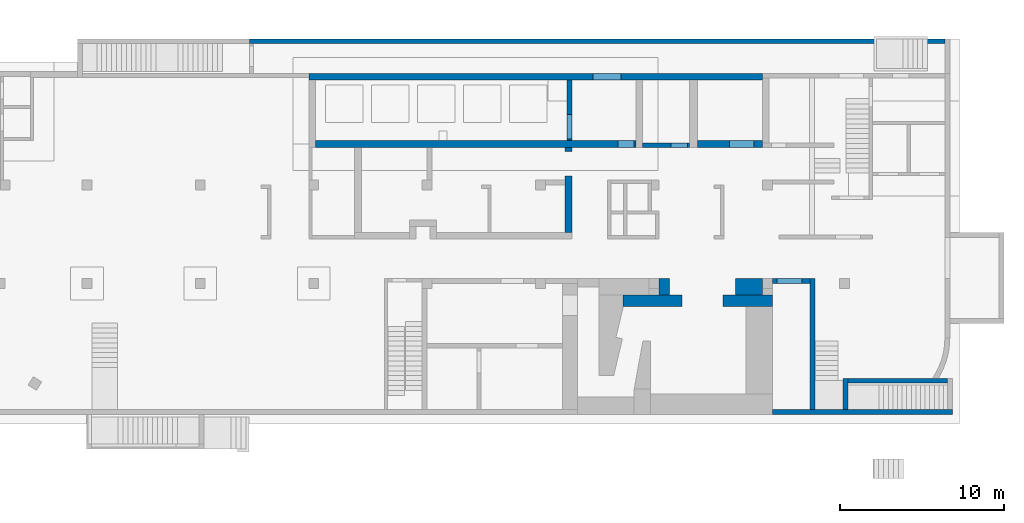
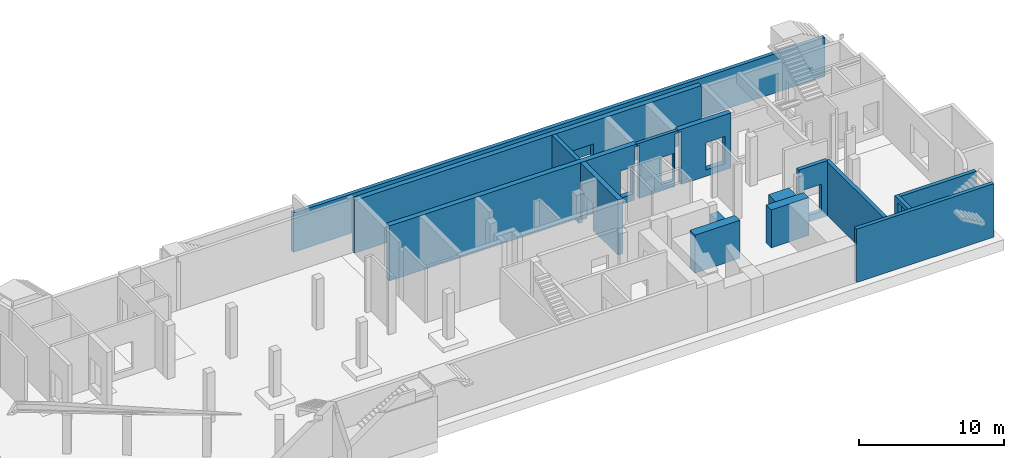
# One storey, part 7 of 9: 16 walls, 8 openings.
"""IFC4 building model written with IfcOpenShell, lengths in millimetres."""

from ifc_helpers import new_model, entity, si_unit, converted_unit, derived_unit, direction, frame, origin, place, context, subcontext, project, spatial, indexed_curve, outline, extrude, triangles, polygons, material, type_object, element, save


model = new_model("IFC4")

# Units and contexts
model_context = context("Model", 3, precision=0.01, world=origin(), true_north=direction((6.12303176911189e-17, 1.0)))
plan_context = context("Plan", 3, precision=0.01, world=origin(), true_north=direction((6.12303176911189e-17, 1.0)))
body_context = subcontext(model_context, "Body", "Model", "MODEL_VIEW")
ifc_project = project(units=[si_unit("LENGTHUNIT", "METRE", prefix="MILLI"), si_unit("AREAUNIT", "SQUARE_METRE"), si_unit("VOLUMEUNIT", "CUBIC_METRE"), converted_unit("PLANEANGLEUNIT", "DEGREE", entity("IfcRatioMeasure", 0.0174532925199433), si_unit("PLANEANGLEUNIT", "RADIAN"), dimensions=[0, 0, 0, 0, 0, 0, 0]), si_unit("MASSUNIT", "GRAM", prefix="KILO"), derived_unit("MASSDENSITYUNIT", [(si_unit("MASSUNIT", "GRAM", prefix="KILO"), 1), (si_unit("LENGTHUNIT", "METRE"), -3)]), derived_unit("MOMENTOFINERTIAUNIT", [(si_unit("LENGTHUNIT", "METRE"), 4)]), si_unit("TIMEUNIT", "SECOND"), si_unit("FREQUENCYUNIT", "HERTZ"), si_unit("THERMODYNAMICTEMPERATUREUNIT", "DEGREE_CELSIUS"), derived_unit("THERMALTRANSMITTANCEUNIT", [(si_unit("MASSUNIT", "GRAM", prefix="KILO"), 1), (si_unit("THERMODYNAMICTEMPERATUREUNIT", "KELVIN"), -1), (si_unit("TIMEUNIT", "SECOND"), -3)]), derived_unit("VOLUMETRICFLOWRATEUNIT", [(si_unit("LENGTHUNIT", "METRE"), 3), (si_unit("TIMEUNIT", "SECOND"), -1)]), derived_unit("MASSFLOWRATEUNIT", [(si_unit("MASSUNIT", "GRAM", prefix="KILO"), 1), (si_unit("TIMEUNIT", "SECOND"), -1)]), derived_unit("ROTATIONALFREQUENCYUNIT", [(si_unit("TIMEUNIT", "SECOND"), -1)]), si_unit("ELECTRICCURRENTUNIT", "AMPERE"), si_unit("ELECTRICVOLTAGEUNIT", "VOLT"), si_unit("POWERUNIT", "WATT"), si_unit("FORCEUNIT", "NEWTON", prefix="KILO"), si_unit("ILLUMINANCEUNIT", "LUX"), si_unit("LUMINOUSFLUXUNIT", "LUMEN"), si_unit("LUMINOUSINTENSITYUNIT", "CANDELA"), derived_unit("USERDEFINED", [(si_unit("MASSUNIT", "GRAM", prefix="KILO"), -1), (si_unit("LENGTHUNIT", "METRE"), -2), (si_unit("TIMEUNIT", "SECOND"), 3), (si_unit("LUMINOUSFLUXUNIT", "LUMEN"), 1)]), derived_unit("LINEARVELOCITYUNIT", [(si_unit("LENGTHUNIT", "METRE"), 1), (si_unit("TIMEUNIT", "SECOND"), -1)]), si_unit("PRESSUREUNIT", "PASCAL"), derived_unit("USERDEFINED", [(si_unit("LENGTHUNIT", "METRE"), -2), (si_unit("MASSUNIT", "GRAM", prefix="KILO"), 1), (si_unit("TIMEUNIT", "SECOND"), -2)]), derived_unit("LINEARFORCEUNIT", [(si_unit("MASSUNIT", "GRAM", prefix="KILO"), 1), (si_unit("LENGTHUNIT", "METRE"), 1), (si_unit("TIMEUNIT", "SECOND"), -2), (si_unit("LENGTHUNIT", "METRE"), -1)]), derived_unit("PLANARFORCEUNIT", [(si_unit("MASSUNIT", "GRAM", prefix="KILO"), 1), (si_unit("LENGTHUNIT", "METRE"), 1), (si_unit("TIMEUNIT", "SECOND"), -2), (si_unit("LENGTHUNIT", "METRE"), -2)])], contexts=[model_context, plan_context])

# Site, building, storey
site_placement = place(None, origin())
site = spatial("IfcSite", under=ifc_project, at=site_placement, CompositionType="ELEMENT")
building_placement = place(site_placement, origin())
building = spatial("IfcBuilding", under=site, at=building_placement, CompositionType="ELEMENT")
storey_placement = place(building_placement, frame((0.0, 0.0, -4900.0)))
storey = spatial("IfcBuildingStorey", under=building, at=storey_placement, CompositionType="ELEMENT", Elevation=-4900.0)

# Walls
ifc_material = material()
wall_type_1 = type_object("IfcWallType", Name=":ADSK_ 25_300", PredefinedType="STANDARD")
wall_1_placement = place(storey_placement, frame((62870.0, -100.0, 0.0)))
element("IfcWall", 1, at=wall_1_placement, inside=storey, type_object=wall_type_1, material=ifc_material, Name=":ADSK_ 25_300", ObjectType=":ADSK_ 25_300", PredefinedType="NOTDEFINED", context=body_context, shape_type="Tessellation", body=[
    polygons([(1.69593855051474e-12, -150.0, 0.0), (10955.0, -150.0, 0.0), (10955.0, -150.0, 4500.0), (4600.0, -150.0, 4500.0), (1.69593855051474e-12, -150.0, 4500.0), (1.69593855051474e-12, -150.0, 3200.0), (-3.39181412269712e-13, 150.0, 0.0), (-3.39181412269712e-13, 150.0, 4500.0), (2300.0, 150.0, 4500.0), (2600.0, 150.0, 4500.0), (4299.99999999999, 150.0, 4500.0), (4600.00000000002, 150.000000000001, 4500.0), (10955.0, 150.0, 4500.0), (10955.0, 150.0, 4229.99999999996), (10955.0, 150.0, 0.0), (10655.0, 150.0, 0.0), (4599.99999999999, 150.0, 0.0), (4299.99999999999, 150.0, 0.0), (2600.0, 150.0, 0.0), (2300.0, 150.0, 0.0)], [[[1, 2, 3, 4, 5, 6]], [[7, 8, 9, 10, 11, 12, 13, 14, 15, 16, 17, 18, 19, 20]], [[2, 1, 7, 20, 19, 18, 17, 16, 15]], [[1, 6, 5, 8, 7]], [[3, 2, 15, 14, 13]], [[4, 3, 13, 12]], [[5, 4, 12, 11, 10, 9, 8]]], closed=True),
])
wall_2_placement = place(storey_placement, frame((65320.0, 50.0, 0.0), z_axis=(0.0, 0.0, 1.0), x_axis=(0.0, 1.0, 0.0)))
element("IfcWall", 2, at=wall_2_placement, inside=storey, type_object=wall_type_1, material=ifc_material, Name=":ADSK_ 25_300", ObjectType=":ADSK_ 25_300", PredefinedType="NOTDEFINED", context=body_context, shape_type="Tessellation", body=[
    polygons([(1.01518793371724e-13, -150.000000000001, 0.0), (7950.00000000001, -150.000000000001, 0.0), (7950.00000000001, -150.000000000001, 4500.0), (3.38395977905748e-14, -150.000000000001, 4500.0), (2.16573425859679e-12, 150.000000000001, 0.0), (2.14035456025385e-12, 150.000000000001, 4500.0), (7950.00000000001, 150.000000000001, 4500.0), (7950.00000000001, 150.000000000001, 0.0), (7650.00000000001, 150.000000000001, 0.0)], [[[1, 2, 3, 4]], [[5, 6, 7, 8, 9]], [[2, 1, 5, 9, 8]], [[3, 2, 8, 7]], [[1, 4, 6, 5]], [[4, 3, 7, 6]]], closed=True),
])

# Wall, opening
wall_3_placement = place(storey_placement, frame((62870.0, 7850.0, 0.0)))
wall_3 = element("IfcWall", 3, at=wall_3_placement, inside=storey, type_object=wall_type_1, material=ifc_material, Name=":ADSK_ 25_300", ObjectType=":ADSK_ 25_300", PredefinedType="NOTDEFINED", context=body_context, shape_type="Tessellation", body=[
    polygons([(2.00999830337293e-12, -149.999999999999, 0.0), (2299.99999999999, -149.999999999998, 0.0), (2299.99999999999, -149.999999999998, 4650.0), (2.00999830337293e-12, -149.999999999999, 4650.0), (299.999999999986, -149.999999999997, 2829.99999999805), (1799.99999999999, -149.999999999998, 2829.99999999804), (1799.99999999999, -149.999999999998, 550.0), (299.999999999986, -149.999999999997, 550.0), (2299.99999999999, 150.000000000002, 0.0), (4.00724627324388e-13, 150.000000000002, 0.0), (4.00724627324396e-13, 150.000000000001, 3200.0), (4.00724627324388e-13, 150.000000000002, 4650.0), (2299.99999999999, 150.000000000002, 4650.0), (2299.99999999999, 150.000000000002, 4500.0), (1799.99999999999, 150.000000000001, 2829.99999999804), (299.999999999993, 150.000000000002, 2829.99999999805), (299.999999999984, 150.000000000002, 550.0), (1799.99999999999, 150.000000000001, 550.0)], [[[1, 2, 3, 4], [5, 6, 7, 8]], [[9, 10, 11, 12, 13, 14], [15, 16, 17, 18]], [[2, 1, 10, 9]], [[4, 3, 13, 12]], [[1, 4, 12, 11, 10]], [[3, 2, 9, 14, 13]], [[5, 16, 15, 6]], [[6, 15, 18, 7]], [[7, 18, 17, 8]], [[16, 5, 8, 17]]], closed=True),
])
opening_1_placement = place(wall_3_placement, frame((-62870.0, -7850.0, 0.0)))
element("IfcOpeningElement", 4, at=opening_1_placement, cuts=wall_3, Name=":ADSK_ 25_300", PredefinedType="OPENING", context=body_context, shape_type="SweptSolid", body=[
    extrude(outline(indexed_curve([(-750.000000000003, -1139.99999999902), (749.999999999994, -1139.99999999902), (749.999999999994, 1139.99999999902), (-750.000000000003, 1139.99999999902), (-750.000000000003, -1139.99999999902)], self_intersect=False)), frame((63920.0, 7600.0, 1690.0), z_axis=(0.0, 1.0, 0.0), x_axis=(1.0, 0.0, 0.0)), (0.0, 0.0, 1.0), 500.000000001943),
])

# Wall
wall_4_placement = place(storey_placement, frame((73525.0, 1795.0, 0.0), z_axis=(0.0, 0.0, 1.0), x_axis=(-1.0, 0.0, 0.0)))
element("IfcWall", 5, at=wall_4_placement, inside=storey, type_object=wall_type_1, material=ifc_material, Name=":ADSK_ 25_300", ObjectType=":ADSK_ 25_300", PredefinedType="NOTDEFINED", context=body_context, shape_type="Tessellation", body=[
    triangles([(547.133825683544, -149.999930977401, 4499.99999694824), (-0.000219726614886895, -149.999930977401, 4229.99998035431), (903.567883300726, -149.999930977401, 0.000253295897891803), (-0.000219726614886895, -149.999930977401, 4499.99999694824), (-0.000219726614886895, -149.999930977401, 0.000253295897891803), (547.138476562439, -149.999930977401, 0.000253295897891803), (6055.00228271479, -149.999930977401, 4499.99999694824), (6055.00228271479, -149.999930977401, 0.000253295897891803), (6055.00228271479, 150.000071311417, 4499.99999694824), (6055.00228271479, 150.000071311417, 0.000253295897891803), (747.116967773385, 150.000071311417, 4499.99999694824), (-0.000219726614886895, 150.000071311417, 0.000253295897891803), (-0.000219726614886895, 150.000071311417, 4499.99999694824), (644.248828124939, 1.91826703590436, 4499.99999694824)], [[1, 2, 3], [1, 4, 2], [2, 5, 6], [7, 1, 3], [7, 3, 8], [3, 2, 6], [9, 10, 11], [11, 12, 13], [12, 11, 10], [6, 5, 12], [3, 12, 10], [12, 3, 6], [3, 10, 8], [13, 12, 2], [5, 2, 12], [4, 13, 2], [8, 10, 9], [9, 7, 8], [4, 1, 13], [14, 11, 13], [14, 13, 1], [7, 11, 14], [1, 7, 14], [9, 11, 7]]),
])

# Wall, opening
wall_5_placement = place(storey_placement, frame((67320.0, 1945.0, 0.0), z_axis=(0.0, 0.0, 1.0), x_axis=(0.0, -1.0, 0.0)))
wall_5 = element("IfcWall", 6, at=wall_5_placement, inside=storey, type_object=wall_type_1, material=ifc_material, Name=":ADSK_ 25_300", ObjectType=":ADSK_ 25_300", PredefinedType="NOTDEFINED", context=body_context, shape_type="Tessellation", body=[
    polygons([(0.0, -150.000000000001, 0.0), (1894.99999999998, -150.000000000001, 0.0), (1894.99999999998, -150.000000000001, 4500.0), (0.0, -150.000000000001, 4500.0), (472.499999999996, -150.000000000001, 4179.99999999804), (1722.5, -150.000000000001, 4179.99999999804), (1722.5, -150.000000000001, 1825.0), (472.499999999996, -150.000000000001, 1825.0), (1894.99999999998, 150.000000000001, 0.0), (300.0, 150.000000000001, 0.0), (0.0, 150.000000000001, 0.0), (0.0, 150.000000000001, 4500.0), (299.999999999991, 150.000000000001, 4500.0), (1894.99999999998, 150.000000000001, 4500.0), (1722.5, 150.000000000001, 4179.99999999804), (472.499999999996, 150.000000000001, 4179.99999999804), (472.499999999996, 150.000000000001, 1825.0), (1722.5, 150.000000000001, 1825.0)], [[[1, 2, 3, 4], [5, 6, 7, 8]], [[9, 10, 11, 12, 13, 14], [15, 16, 17, 18]], [[2, 1, 11, 10, 9]], [[3, 2, 9, 14]], [[1, 4, 12, 11]], [[12, 4, 3, 14, 13]], [[5, 16, 15, 6]], [[6, 15, 18, 7]], [[7, 18, 17, 8]], [[16, 5, 8, 17]]], closed=True),
])
opening_2_placement = place(wall_5_placement, frame((1945.0, -67320.0, 0.0), z_axis=(0.0, 0.0, 1.0), x_axis=(0.0, 1.0, 0.0)))
element("IfcOpeningElement", 7, at=opening_2_placement, cuts=wall_5, Name=":ADSK_ 25_300", PredefinedType="OPENING", context=body_context, shape_type="SweptSolid", body=[
    extrude(outline(indexed_curve([(-625.0, -1177.49999999902), (625.0, -1177.49999999902), (625.0, 1177.49999999902), (-625.0, 1177.49999999902), (-625.0, -1177.49999999902)], self_intersect=False)), frame((67070.0, 847.5, 3002.5), z_axis=(1.0, 0.0, 0.0), x_axis=(0.0, -1.0, 0.0)), (0.0, 0.0, 1.0), 500.000000001948),
])

# Wall
wall_6_placement = place(storey_placement, frame((73370.0, 22450.0, 0.0), z_axis=(0.0, 0.0, 1.0), x_axis=(-1.0, 0.0, 0.0)))
element("IfcWall", 8, at=wall_6_placement, inside=storey, type_object=wall_type_1, material=ifc_material, Name=":ADSK_ 25_300", ObjectType=":ADSK_ 25_300", PredefinedType="NOTDEFINED", context=body_context, shape_type="Tessellation", body=[
    polygons([(5.41415833087696e-13, -150.000000000001, 0.0), (42310.0, -149.999999999996, 0.0), (42310.0, -149.999999999996, 3300.0), (5.41415833087696e-13, -150.000000000001, 3300.0), (-2.70734306312946e-13, 150.000000000001, 0.0), (-2.70734306312946e-13, 150.000000000001, 3300.0), (42060.0, 150.000000000001, 3300.0), (42310.0, 150.000000000005, 3300.0), (42310.0, 150.000000000005, 0.0), (42060.0, 150.000000000001, 0.0)], [[[1, 2, 3, 4]], [[5, 6, 7, 8, 9, 10]], [[2, 1, 5, 10, 9]], [[1, 4, 6, 5]], [[4, 3, 8, 7, 6]], [[3, 2, 9, 8]]], closed=True),
])

# Wall, opening
wall_7_placement = place(storey_placement, frame((50520.0, 20100.0, -750.0), z_axis=(0.0, 0.0, 1.0), x_axis=(0.0, -1.0, 0.0)))
wall_7 = element("IfcWall", 9, at=wall_7_placement, inside=storey, type_object=wall_type_1, material=ifc_material, Name=":ADSK_ 25_300", ObjectType=":ADSK_ 25_300", PredefinedType="NOTDEFINED", context=body_context, shape_type="Tessellation", body=[
    polygons([(3700.00000000001, -149.999999999999, 5200.0), (0.0, -150.0, 5200.0), (0.0, -150.0, 749.999999999998), (0.0, -150.0, 0.0), (1299.99999999996, -149.999999999997, 0.0), (3700.00000000001, -149.999999999999, 0.0), (3700.00000000001, -149.999999999999, 749.999999999998), (2100.00000000001, -150.000000000004, 2379.99999999804), (3600.00000000001, -150.0, 2379.99999999804), (3600.00000000001, -150.0, 249.999999999999), (2100.00000000001, -150.000000000004, 249.999999999999), (3700.00000000001, 150.000000000002, 0.0), (0.0, 150.000000000001, 0.0), (0.0, 150.000000000001, 749.999999999998), (0.0, 150.000000000001, 5200.0), (3700.00000000001, 150.000000000002, 5200.0), (3700.00000000001, 150.000000000002, 749.999999999998), (3600.00000000001, 150.000000000001, 2379.99999999804), (2100.00000000001, 150.000000000006, 2379.99999999804), (2100.00000000001, 150.000000000006, 249.999999999999), (3600.00000000001, 150.000000000001, 249.999999999999)], [[[1, 2, 3, 4, 5, 6, 7], [8, 9, 10, 11]], [[12, 13, 14, 15, 16, 17], [18, 19, 20, 21]], [[13, 12, 6, 5, 4]], [[2, 1, 16, 15]], [[2, 15, 14, 13, 4, 3]], [[6, 12, 17, 16, 1, 7]], [[18, 9, 8, 19]], [[11, 20, 19, 8]], [[20, 11, 10, 21]], [[21, 10, 9, 18]]], closed=True),
])
opening_3_placement = place(wall_7_placement, frame((20100.0, -50520.0, 750.0), z_axis=(0.0, 0.0, 1.0), x_axis=(0.0, 1.0, 0.0)))
element("IfcOpeningElement", 10, at=opening_3_placement, cuts=wall_7, Name=":ADSK_ 25_300", PredefinedType="OPENING", context=body_context, shape_type="SweptSolid", body=[
    extrude(outline(indexed_curve([(-1064.99999999902, -749.999999999998), (1064.99999999902, -749.999999999998), (1064.99999999902, 750.000000000001), (-1064.99999999902, 750.000000000001), (-1064.99999999902, -749.999999999998)], self_intersect=False)), frame((50270.0, 17250.0, 565.0), z_axis=(1.0, 0.0, 0.0), x_axis=(0.0, 0.0, -1.0)), (0.0, 0.0, 1.0), 500.000000001948),
])

# Walls
wall_type_2 = type_object("IfcWallType", Name=":ADSK_ 25_700", PredefinedType="STANDARD")
wall_8_placement = place(storey_placement, frame((53803.24, 6650.0, 0.0)))
element("IfcWall", 11, at=wall_8_placement, inside=storey, type_object=wall_type_2, material=ifc_material, Name=":ADSK_ 25_700", ObjectType=":ADSK_ 25_700", PredefinedType="NOTDEFINED", context=body_context, shape_type="Tessellation", body=[
    polygons([(1.11788315284292e-13, -349.999999999999, 0.0), (3566.7626832281, -349.999999999999, 0.0), (3566.7626832281, -349.999999999999, 3200.0), (1.11788315284292e-13, -349.999999999999, 3200.0), (-1.8008881144258e-12, 350.000000000002, 0.0), (-1.80088811442579e-12, 350.000000000001, 3000.0), (-1.8008881144258e-12, 350.000000000002, 3200.0), (2166.76268322811, 349.999999999999, 3200.0), (2816.76268322809, 350.000000000001, 3200.0), (3566.76268322809, 350.000000000001, 3200.0), (3566.76268322809, 350.000000000001, 0.0), (2816.76268322809, 350.000000000001, 0.0), (2166.76268322811, 349.999999999999, 0.0), (1566.76268322811, 350.000000000001, 0.0)], [[[1, 2, 3, 4]], [[5, 6, 7, 8, 9, 10, 11, 12, 13, 14]], [[2, 1, 5, 14, 13, 12, 11]], [[3, 2, 11, 10]], [[1, 4, 7, 6, 5]], [[4, 3, 10, 9, 8, 7]]], closed=True),
])
wall_9_placement = place(storey_placement, frame((59870.0, 6650.0, 0.0)))
element("IfcWall", 12, at=wall_9_placement, inside=storey, type_object=wall_type_2, material=ifc_material, Name=":ADSK_ 25_700", ObjectType=":ADSK_ 25_700", PredefinedType="NOTDEFINED", context=body_context, shape_type="Tessellation", body=[
    polygons([(4.28224994962343e-12, -349.999999999999, 0.0), (1400.00000000002, -349.999999999999, 0.0), (3000.00000000002, -349.999999999999, 0.0), (3000.00000000002, -349.999999999999, 3200.0), (1400.00000000002, -349.999999999999, 3200.0), (4.28224994962343e-12, -349.999999999999, 3200.0), (1.87040952527702e-12, 350.000000000002, 0.0), (1.87040952527702e-12, 350.000000000002, 3200.0), (750.000000000005, 350.000000000001, 3200.0), (2400.00000000002, 350.000000000001, 3200.0), (3000.00000000004, 350.000000000001, 3200.0), (3000.00000000001, 350.000000000001, 0.0), (2400.00000000002, 350.000000000001, 0.0), (750.000000000005, 350.000000000001, 0.0)], [[[1, 2, 3, 4, 5, 6]], [[7, 8, 9, 10, 11, 12, 13, 14]], [[3, 2, 1, 7, 14, 13, 12]], [[1, 6, 8, 7]], [[4, 3, 12, 11]], [[6, 5, 4, 11, 10, 9, 8]]], closed=True),
])

# Wall, opening
wall_type_3 = type_object("IfcWallType", Name=":ADSK_ 25_250", PredefinedType="STANDARD")
wall_10_placement = place(storey_placement, frame((58070.0, 16125.0, 0.0), z_axis=(0.0, 0.0, 1.0), x_axis=(-1.0, 0.0, 0.0)))
wall_10 = element("IfcWall", 13, at=wall_10_placement, inside=storey, type_object=wall_type_3, material=ifc_material, Name=":ADSK_ 25_250", ObjectType=":ADSK_ 25_250", PredefinedType="NOTDEFINED", context=body_context, shape_type="Tessellation", body=[
    polygons([(249.999999999995, -125.000000000002, 0.0), (3100.00000000002, -124.999999999995, 0.0), (3100.00000000002, -125.0, 4450.0), (3300.00000000001, -124.999999999995, 4450.0), (3300.00000000001, -124.999999999995, 4650.0), (1.70289415178989e-13, -125.000000000002, 4650.0), (1.70289415178989e-13, -125.000000000002, 4450.0), (249.999999999995, -125.000000000002, 4450.0), (349.999999999999, -125.000000000002, 2829.99999999805), (1349.99999999999, -125.0, 2829.99999999804), (1349.99999999999, -125.0, 550.0), (349.999999999999, -125.000000000002, 550.0), (3100.00000000002, 125.000000000002, 0.0), (249.999999999995, 125.0, 0.0), (249.999999999995, 125.0, 4450.0), (-6.31986186424167e-13, 125.0, 4450.0), (-6.31986186424167e-13, 125.0, 4650.0), (3300.00000000001, 125.000000000002, 4650.0), (3300.00000000001, 125.000000000002, 4450.0), (3100.00000000002, 125.000000000002, 4450.0), (1349.99999999999, 124.999999999998, 2829.99999999804), (349.999999999998, 125.0, 2829.99999999805), (349.999999999998, 125.0, 550.0), (1349.99999999999, 124.999999999998, 550.0)], [[[1, 2, 3, 4, 5, 6, 7, 8], [9, 10, 11, 12]], [[13, 14, 15, 16, 17, 18, 19, 20], [21, 22, 23, 24]], [[2, 1, 14, 13]], [[6, 5, 18, 17]], [[9, 22, 21, 10]], [[10, 21, 24, 11]], [[11, 24, 23, 12]], [[22, 9, 12, 23]], [[18, 5, 4, 19]], [[19, 4, 3, 20]], [[2, 13, 20, 3]], [[6, 17, 16, 7]], [[7, 16, 15, 8]], [[14, 1, 8, 15]]], closed=True),
])
opening_4_placement = place(wall_10_placement, frame((58070.0, 16125.0, 0.0), z_axis=(0.0, 0.0, 1.0), x_axis=(-1.0, 0.0, 0.0)))
element("IfcOpeningElement", 14, at=opening_4_placement, cuts=wall_10, Name=":ADSK_ 25_250", PredefinedType="OPENING", context=body_context, shape_type="SweptSolid", body=[
    extrude(outline(indexed_curve([(-499.999999999999, -1139.99999999902), (499.999999999999, -1139.99999999902), (499.999999999999, 1139.99999999902), (-499.999999999999, 1139.99999999902), (-499.999999999999, -1139.99999999902)], self_intersect=False)), frame((57220.0, 16350.0, 1690.0), z_axis=(0.0, -1.0, 0.0), x_axis=(-1.0, 0.0, 0.0)), (0.0, 0.0, 1.0), 450.000000000965),
])

# Walls
wall_type_4 = type_object("IfcWallType", Name=":ADSK_ 25_1000", PredefinedType="STANDARD")
wall_11_placement = place(storey_placement, frame((55970.0, 7500.0, 0.0)))
element("IfcWall", 15, at=wall_11_placement, inside=storey, type_object=wall_type_4, material=ifc_material, Name=":ADSK_ 25_1000", ObjectType=":ADSK_ 25_1000", PredefinedType="NOTDEFINED", context=body_context, shape_type="Tessellation", body=[
    polygons([(2.66552166520652e-12, -500.0, 0.0), (649.999999999985, -500.0, 0.0), (649.999999999985, -500.0, 3200.0), (2.66552166520652e-12, -500.0, 3200.0), (649.999999999981, 500.0, 0.0), (-6.66377194173235e-13, 500.0, 0.0), (-6.66377194173235e-13, 500.0, 3200.0), (649.999999999981, 500.0, 3200.0), (1.33276212145463e-12, -100.000000000002, 0.0), (1.33276212145461e-12, -99.9999999999978, 3200.0)], [[[1, 2, 3, 4]], [[5, 6, 7, 8]], [[2, 1, 9, 6, 5]], [[2, 5, 8, 3]], [[6, 9, 1, 4, 10, 7]], [[4, 3, 8, 7, 10]]], closed=True),
])
wall_12_placement = place(storey_placement, frame((60620.0, 7500.0, 0.0)))
element("IfcWall", 16, at=wall_12_placement, inside=storey, type_object=wall_type_4, material=ifc_material, Name=":ADSK_ 25_1000", ObjectType=":ADSK_ 25_1000", PredefinedType="NOTDEFINED", context=body_context, shape_type="Tessellation", body=[
    polygons([(-1.57507641442058e-12, -500.0, 0.0), (1650.00000000001, -500.000000000001, 0.0), (1650.00000000001, -500.000000000001, 3200.0), (-1.57507641442058e-12, -500.0, 3200.0), (1650.00000000001, 500.0, 0.0), (-5.51277506641469e-12, 499.999999999999, 0.0), (-5.51277506641469e-12, 499.999999999999, 3200.0), (1650.00000000001, 500.0, 3200.0), (1650.00000000001, -99.9999999999989, 0.0), (1650.00000000001, -99.9999999999989, 3200.0)], [[[1, 2, 3, 4]], [[5, 6, 7, 8]], [[2, 1, 6, 5, 9]], [[2, 9, 5, 8, 10, 3]], [[6, 1, 4, 7]], [[4, 3, 10, 8, 7]]], closed=True),
])

# Wall, opening
wall_type_5 = type_object("IfcWallType", Name=":ADSK_ 25_400", PredefinedType="STANDARD")
wall_13_placement = place(storey_placement, frame((62270.0, 20300.0, 0.0), z_axis=(0.0, 0.0, 1.0), x_axis=(-1.0, 0.0, 0.0)))
wall_13 = element("IfcWall", 17, at=wall_13_placement, inside=storey, type_object=wall_type_5, material=ifc_material, Name=":ADSK_ 25_400", ObjectType=":ADSK_ 25_400", PredefinedType="NOTDEFINED", context=body_context, shape_type="Tessellation", body=[
    polygons([(3.98557861925833e-13, -200.000000000002, 0.0), (27600.0, -200.000000000002, 0.0), (27600.0, -200.000000000002, 4450.0), (27200.0, -200.000000000002, 4450.0), (3.98557861925833e-13, -200.000000000002, 4450.0), (3.98557861925833e-13, -200.000000000002, 4170.0), (8600.00000000001, -200.000000000323, 2550.0), (10300.0, -200.000000000323, 2550.0), (10300.0, -200.000000000323, 850.00000000001), (8600.00000000001, -200.000000000323, 850.00000000001), (-9.61482270122758e-13, 199.999999999998, 0.0), (-9.61482270122758e-13, 199.999999999998, 4450.0), (3950.0, 199.999999999998, 4450.0), (4450.0, 200.000000000002, 4450.0), (7300.00000000002, 199.999999999998, 4450.0), (7700.00000000002, 199.999999999998, 4450.0), (11600.0, 199.999999999998, 4450.0), (11900.0, 199.999999999998, 4450.0), (27200.0, 199.999999999998, 4450.0), (27600.0, 199.999999999998, 4450.0), (27600.0, 199.999999999998, 0.0), (27200.0, 199.999999999998, 0.0), (7700.00000000002, 199.999999999998, 0.0), (7300.00000000002, 199.999999999998, 0.0), (4450.0, 200.000000000002, 0.0), (3950.0, 199.999999999998, 0.0), (10300.0, 199.999999999998, 2550.0), (8600.00000000001, 199.999999999998, 2550.0), (8600.00000000001, 199.999999999998, 850.00000000001), (10300.0, 199.999999999998, 850.00000000001), (-6.21472237110631e-13, 100.000000000003, 0.0), (27600.0, 50.0000000000016, 0.0)], [[[1, 2, 3, 4, 5, 6], [7, 8, 9, 10]], [[11, 12, 13, 14, 15, 16, 17, 18, 19, 20, 21, 22, 23, 24, 25, 26], [27, 28, 29, 30]], [[2, 1, 31, 11, 26, 25, 24, 23, 22, 21, 32]], [[5, 4, 3, 20, 19, 18, 17, 16, 15, 14, 13, 12]], [[1, 6, 5, 12, 11, 31]], [[3, 2, 32, 21, 20]], [[8, 7, 28, 27]], [[8, 27, 30, 9]], [[9, 30, 29, 10]], [[28, 7, 10, 29]]], closed=True),
])
opening_5_placement = place(wall_13_placement, frame((62270.0, 20300.0, 0.0), z_axis=(0.0, 0.0, 1.0), x_axis=(-1.0, 0.0, 0.0)))
element("IfcOpeningElement", 18, at=opening_5_placement, cuts=wall_13, Name=":ADSK_ 25_400", PredefinedType="OPENING", context=body_context, shape_type="SweptSolid", body=[
    extrude(outline(indexed_curve([(-849.999999999997, -849.999999999994), (850.000000000006, -849.999999999994), (850.000000000006, 849.999999999994), (-849.999999999997, 849.999999999994), (-849.999999999997, -849.999999999994)], self_intersect=False)), frame((52820.0, 20500.0, 1700.0), z_axis=(0.0, -1.0, 0.0), x_axis=(-1.0, 0.0, 0.0)), (0.0, 0.0, 1.0), 400.000000000962),
])

wall_14_placement = place(storey_placement, frame((62270.0, 16200.0, 0.0), z_axis=(0.0, 0.0, 1.0), x_axis=(-1.0, 0.0, 0.0)))
wall_14 = element("IfcWall", 19, at=wall_14_placement, inside=storey, type_object=wall_type_5, material=ifc_material, Name=":ADSK_ 25_400", ObjectType=":ADSK_ 25_400", PredefinedType="NOTDEFINED", context=body_context, shape_type="Tessellation", body=[
    polygons([(-1.23756482706569e-12, -200.0, 0.0), (3949.99999999999, -200.0, 0.0), (3949.99999999999, -200.0, 4450.0), (4200.0, -200.0, 4450.0), (4200.0, -200.0, 4650.0), (-1.23756482706569e-12, -200.0, 4650.0), (499.999999999989, -200.0, 2829.99999999805), (1999.99999999999, -199.999999999998, 2829.99999999804), (1999.99999999999, -199.999999999998, 550.0), (499.999999999989, -200.0, 550.0), (3949.99999999999, 200.0, 0.0), (-2.47512726054956e-12, 200.0, 0.0), (-2.47512726054956e-12, 200.0, 4170.0), (-2.47512726054956e-12, 200.0, 4450.0), (-2.47512726054956e-12, 200.0, 4650.0), (4200.0, 200.0, 4650.0), (4200.0, 200.0, 4450.0), (3949.99999999999, 200.0, 4450.0), (1999.99999999999, 200.0, 2829.99999999804), (499.999999999988, 199.999999999998, 2829.99999999805), (499.999999999988, 199.999999999998, 550.0), (1999.99999999999, 200.0, 550.0), (-1.70165073962216e-12, -49.9999999999973, 0.0), (4200.0, -50.0000000000016, 4650.0), (4200.0, -50.0000000000016, 4450.0)], [[[1, 2, 3, 4, 5, 6], [7, 8, 9, 10]], [[11, 12, 13, 14, 15, 16, 17, 18], [19, 20, 21, 22]], [[2, 1, 23, 12, 11]], [[6, 5, 24, 16, 15]], [[1, 6, 15, 14, 13, 12, 23]], [[7, 20, 19, 8]], [[8, 19, 22, 9]], [[9, 22, 21, 10]], [[20, 7, 10, 21]], [[16, 24, 5, 4, 25, 17]], [[17, 25, 4, 3, 18]], [[2, 11, 18, 3]]], closed=True),
])
opening_6_placement = place(wall_14_placement, frame((62270.0, 16200.0, 0.0), z_axis=(0.0, 0.0, 1.0), x_axis=(-1.0, 0.0, 0.0)))
element("IfcOpeningElement", 20, at=opening_6_placement, cuts=wall_14, Name=":ADSK_ 25_400", PredefinedType="OPENING", context=body_context, shape_type="SweptSolid", body=[
    extrude(outline(indexed_curve([(-749.999999999994, -1139.99999999902), (750.000000000003, -1139.99999999902), (750.000000000003, 1139.99999999902), (-749.999999999994, 1139.99999999902), (-749.999999999994, -1139.99999999902)], self_intersect=False)), frame((61020.0, 16500.0, 1690.0), z_axis=(0.0, -1.0, 0.0), x_axis=(-1.0, 0.0, 0.0)), (0.0, 0.0, 1.0), 600.000000001943),
])

wall_15_placement = place(storey_placement, frame((54770.0, 16200.0, 0.0), z_axis=(0.0, 0.0, 1.0), x_axis=(-1.0, 0.0, 0.0)))
wall_15 = element("IfcWall", 21, at=wall_15_placement, inside=storey, type_object=wall_type_5, material=ifc_material, Name=":ADSK_ 25_400", ObjectType=":ADSK_ 25_400", PredefinedType="NOTDEFINED", context=body_context, shape_type="Tessellation", body=[
    polygons([(199.999999999998, -200.0, 0.0), (19700.0, -200.0, 0.0), (19700.0, -200.0, 4650.0), (5.72325115210965e-13, -200.0, 4650.0), (5.72325115210965e-13, -200.0, 4450.0), (199.999999999998, -200.0, 4450.0), (299.999999999984, -200.0, 2829.99999999805), (1299.99999999999, -199.999999999998, 2829.99999999804), (1299.99999999999, -199.999999999998, 550.0), (299.999999999984, -200.0, 550.0), (19700.0, 199.999999999998, 0.0), (17305.0, 200.000000000002, 0.0), (16905.0, 200.0, 0.0), (12900.0, 200.0, 0.0), (12600.0, 200.000000000002, 0.0), (4499.99999999999, 200.000000000002, 0.0), (4099.99999999999, 200.0, 0.0), (199.999999999997, 200.0, 0.0), (199.999999999997, 200.0, 4450.0), (-7.09380977484016e-13, 200.0, 4450.0), (-7.09380977484016e-13, 200.0, 4650.0), (4099.99999999999, 200.0, 4650.0), (4499.99999999999, 200.000000000002, 4650.0), (12600.0, 200.000000000002, 4650.0), (12900.0, 200.0, 4650.0), (16905.0, 200.0, 4650.0), (17305.0, 200.000000000002, 4650.0), (19700.0, 199.999999999998, 4650.0), (1299.99999999999, 200.0, 2829.99999999804), (299.999999999983, 200.0, 2829.99999999805), (299.999999999983, 200.0, 550.0), (1299.99999999999, 200.0, 550.0), (9.16853304503353e-14, -49.9999999999973, 4650.0), (9.16853304503353e-14, -49.9999999999973, 4450.0)], [[[1, 2, 3, 4, 5, 6], [7, 8, 9, 10]], [[11, 12, 13, 14, 15, 16, 17, 18, 19, 20, 21, 22, 23, 24, 25, 26, 27, 28], [29, 30, 31, 32]], [[2, 1, 18, 17, 16, 15, 14, 13, 12, 11]], [[4, 3, 28, 27, 26, 25, 24, 23, 22, 21, 33]], [[3, 2, 11, 28]], [[7, 30, 29, 8]], [[8, 29, 32, 9]], [[9, 32, 31, 10]], [[30, 7, 10, 31]], [[4, 33, 21, 20, 34, 5]], [[5, 34, 20, 19, 6]], [[18, 1, 6, 19]]], closed=True),
])
opening_7_placement = place(wall_15_placement, frame((54770.0, 16200.0, 0.0), z_axis=(0.0, 0.0, 1.0), x_axis=(-1.0, 0.0, 0.0)))
element("IfcOpeningElement", 22, at=opening_7_placement, cuts=wall_15, Name=":ADSK_ 25_400", PredefinedType="OPENING", context=body_context, shape_type="SweptSolid", body=[
    extrude(outline(indexed_curve([(-500.000000000008, -1139.99999999902), (499.99999999999, -1139.99999999902), (499.99999999999, 1139.99999999902), (-500.000000000008, 1139.99999999902), (-500.000000000008, -1139.99999999902)], self_intersect=False)), frame((53970.0, 16500.0, 1690.0), z_axis=(0.0, -1.0, 0.0), x_axis=(-1.0, 0.0, 0.0)), (0.0, 0.0, 1.0), 600.000000001943),
])

wall_16_placement = place(storey_placement, frame((50470.0, 16000.0, 0.0), z_axis=(0.0, 0.0, 1.0), x_axis=(0.0, -1.0, 0.0)))
wall_16 = element("IfcWall", 23, at=wall_16_placement, inside=storey, type_object=wall_type_5, material=ifc_material, Name=":ADSK_ 25_400", ObjectType=":ADSK_ 25_400", PredefinedType="NOTDEFINED", context=body_context, shape_type="Tessellation", body=[
    polygons([(5174.99999999991, -199.999999999997, 4650.0), (2299.99999999981, -199.999999999993, 4650.0), (1999.99999999982, -199.999999999994, 4650.0), (0.0, -199.999999999997, 4650.0), (2.16573425859679e-12, -199.999999999997, 0.0), (249.999999999815, -199.999999999996, 0.0), (249.999999999813, -199.999999999996, 2279.99999999804), (1749.99999999981, -199.999999999994, 2279.99999999804), (1749.99999999981, -199.999999999994, 0.0), (1999.99999999981, -199.999999999994, 0.0), (2299.99999999981, -199.999999999993, 0.0), (5174.99999999991, -199.999999999997, 0.0), (2.16573425859679e-12, 199.999999999999, 4650.0), (5174.99999999991, 199.999999999998, 4650.0), (5174.99999999991, 199.999999999998, 0.0), (1749.99999999981, 200.000000000002, 0.0), (1749.99999999981, 200.000000000002, 2279.99999999804), (249.999999999813, 199.999999999999, 2279.99999999804), (249.999999999815, 199.999999999999, 0.0), (2.16573425859679e-12, 199.999999999999, 0.0)], [[[1, 2, 3, 4, 5, 6, 7, 8, 9, 10, 11, 12]], [[13, 14, 15, 16, 17, 18, 19, 20]], [[5, 20, 19, 6]], [[4, 3, 2, 1, 14, 13]], [[5, 4, 13, 20]], [[1, 12, 15, 14]], [[7, 18, 17, 8]], [[8, 17, 16, 9]], [[18, 7, 6, 19]], [[15, 12, 11, 10, 9, 16]]], closed=True),
])
opening_8_placement = place(wall_16_placement, frame((16000.0, -50470.0, 0.0), z_axis=(0.0, 0.0, 1.0), x_axis=(0.0, 1.0, 0.0)))
element("IfcOpeningElement", 24, at=opening_8_placement, cuts=wall_16, Name=":ADSK_ 25_400", PredefinedType="OPENING", context=body_context, shape_type="SweptSolid", body=[
    extrude(outline(indexed_curve([(-750.000000000001, -1139.99999999902), (749.999999999998, -1139.99999999902), (749.999999999998, 1139.99999999902), (-750.000000000001, 1139.99999999902), (-750.000000000001, -1139.99999999902)], self_intersect=False)), frame((50170.0, 15000.0, 1140.0), z_axis=(1.0, 0.0, 0.0), x_axis=(0.0, -1.0, 0.0)), (0.0, 0.0, 1.0), 600.000000001943),
])

save(model, "model.ifc")
